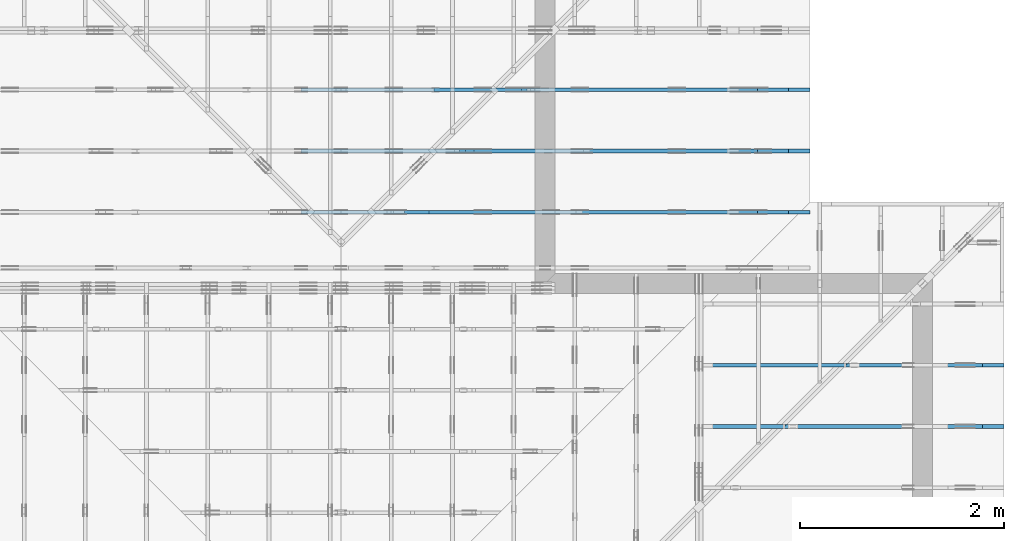
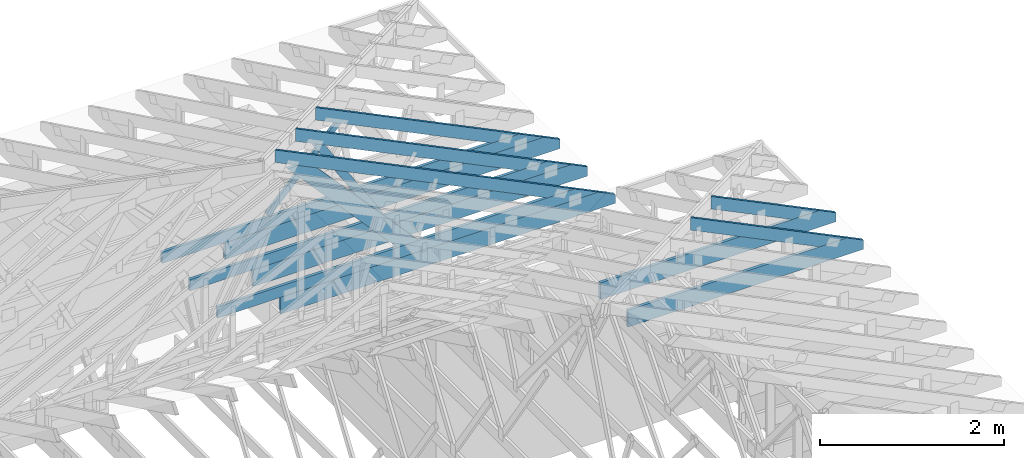
# One storey, part 38 of 159: 16 members, 5 elements without a shape of their own.
"""IFC2X3 building model written with IfcOpenShell, lengths in millimetres."""

from ifc_helpers import new_model, si_unit, frame, origin, origin_with_axes, origin_2d, place, context, project, spatial, faceted_brep, element, aggregate, save


model = new_model("IFC2X3")

# Units and contexts
model_context = context("Model", 3, precision=1e-05, world=origin())
plan_context = context("Plan", 2, precision=1e-05, world=origin_2d())
ifc_project = project(units=[si_unit("LENGTHUNIT", "METRE", prefix="MILLI"), si_unit("AREAUNIT", "SQUARE_METRE"), si_unit("VOLUMEUNIT", "CUBIC_METRE"), si_unit("SOLIDANGLEUNIT", "STERADIAN"), si_unit("PLANEANGLEUNIT", "RADIAN"), si_unit("MASSUNIT", "GRAM"), si_unit("TIMEUNIT", "SECOND"), si_unit("THERMODYNAMICTEMPERATUREUNIT", "DEGREE_CELSIUS"), si_unit("LUMINOUSINTENSITYUNIT", "LUMEN")], contexts=[model_context, plan_context])

# Site, building, storey
site_placement = place(None, origin_with_axes())
site = spatial("IfcSite", under=ifc_project, at=site_placement, CompositionType="ELEMENT")
building_placement = place(site_placement, origin_with_axes())
building = spatial("IfcBuilding", under=site, at=building_placement, Name="Plan 1", CompositionType="ELEMENT")
storey_placement = place(building_placement, origin_with_axes())
storey = spatial("IfcBuildingStorey", under=building, at=storey_placement, Name="Etasje 1", CompositionType="ELEMENT", Elevation=0.0)

# Assembly, members
assembly_1_placement = place(storey_placement, frame((19200.01266310149, 9617.999978540158, 1.1021457184401395e-15), z_axis=(1.2246063538223773e-16, 1.0, 6.123031769111886e-17), x_axis=(-1.0, 1.2246063538223773e-16, 0.0)))
assembly_1 = element("IfcElementAssembly", 1, at=assembly_1_placement, inside=storey, Name="V12 (104)", AssemblyPlace="FACTORY", PredefinedType="TRUSS")
member_1_placement = place(assembly_1_placement, frame((579.5051201688683, 237.97844479869957, -36.00000021700302), z_axis=(0.0, 0.0, 1.0), x_axis=(0.8987940462991673, 0.4383711467890768, 0.0)))
member_1 = element("IfcMember", 2, at=member_1_placement, Name="V12-O21", context=model_context, shape_type="Brep", body=[
    faceted_brep([(4174.996635871784, 148.0000008303515, 2.2522947347169975e-06), (4134.942968873926, 147.99999513818932, 35.9999971857585), (4062.7585449218745, 3.219558948330814e-07, 36.000000217002935), (4102.812214864927, 5.684341886080801e-13, -2.2737367544323206e-13), (9.693633614915598e-05, 148.00000032290794, 2.170030199977191e-07), (9.693633614915598e-05, 148.00000032290794, 36.00000021700302), (4134.9429680300855, 148.00000032290768, 36.00000021700302), (4174.9966370059155, 148.00000032290768, 2.170030199977191e-07), (303.4450508112429, 3.2232911451046675e-07, 2.170030199977191e-07), (303.4450508112429, 3.2232911451046675e-07, 36.00000021700302), (7.909811168360648e-05, 148.00000186326932, 36.00000021700302), (7.909811168360648e-05, 148.00000186326932, 2.170030199977191e-07), (4102.812214780502, 3.219505755503753e-07, 2.170030199977191e-07), (4062.7585458046715, 3.219503612912016e-07, 36.00000021700302), (303.44502728050213, 3.219510518430847e-07, 36.00000021700302), (303.44502728050213, 3.2195127345975504e-07, 2.170030199977191e-07), (4134.942970275878, 148.0000003219552, 36.00000021700302), (0.0, 148.0000003219552, 36.00000021700302), (303.4450683593752, 3.2232941293841577e-07, 36.00000021700302), (4062.758544921875, 3.2232941293841577e-07, 36.00000021700302), (5.585746430369909e-05, 148.00000032329382, 2.1700301999772592e-07), (4174.996637888714, 148.00000032329382, 2.1700353127046008e-07), (4102.81221253471, 3.229042704333551e-07, 2.170035224307095e-07), (303.4451242168394, 3.229042704333551e-07, 2.170030571578018e-07)], [[[0, 1, 2, 3]], [[4, 5, 6, 7]], [[8, 9, 10, 11]], [[12, 13, 14, 15]], [[16, 17, 18, 19]], [[20, 21, 22, 23]]]),
])
member_2_placement = place(assembly_1_placement, frame((4991.181295681745, 371.0000000000011, -36.0), z_axis=(0.0, 0.0, 1.0), x_axis=(-1.0, 1.2246063538223773e-16, 0.0)))
member_2 = element("IfcMember", 3, at=member_2_placement, Name="V12-U34", context=model_context, shape_type="Brep", body=[
    faceted_brep([(4780.000006008893, 148.00000000000168, 36.0), (0.00014333799481391907, 148.00000000000168, 36.0), (0.00014333799481391907, 1.0800249583553523e-12, 36.0), (4476.555013943464, 1.0800249583553523e-12, 36.0), (0.00014333799481391907, 148.00000000000168, 1.7553261919328425e-20), (4780.000006008893, 148.00000000000168, 5.853618378629492e-13), (4476.555013943464, 1.0800249583553523e-12, 5.482017713310586e-13), (0.00014333799481391907, 1.0800249583553523e-12, 1.7553261919328425e-20), (0.0, 0.0, 0.0), (2.204291436880279e-15, -2.6993892992798474e-31, 36.0), (2.0328465473451462e-14, 148.0, 36.0), (1.8124174036571183e-14, 148.0, -1.1097489341483817e-30), (4476.555031444877, -8.223026602114393e-13, 1.5128553039240036e-28), (4476.555031444877, -8.20098368774559e-13, 36.0), (4.049083948919771e-31, 2.204291436880279e-15, 36.0), (0.0, 0.0, 0.0), (4780.0, 148.00000000000227, -5.048709793414476e-29), (4780.0, 148.00000000000227, 36.0), (4476.555031444878, 2.5011104298755527e-12, 36.0), (4476.555031444878, 2.5011104298755527e-12, -2.524354896707238e-29), (0.0, 148.0, 0.0), (0.0, 148.0, 36.0), (4780.0, 148.00000000000182, 36.0), (4780.0, 148.00000000000182, 9.466330862652142e-30)], [[[0, 1, 2, 3]], [[4, 5, 6, 7]], [[8, 9, 10, 11]], [[12, 13, 14, 15]], [[16, 17, 18, 19]], [[20, 21, 22, 23]]]),
])
member_3_placement = place(assembly_1_placement, frame((3965.2348718633434, 2028.64517936101, -36.0), z_axis=(0.0, 0.0, 1.0), x_axis=(-0.6709049751762265, -0.741543332708067, 0.0)))
member_3 = element("IfcMember", 4, at=member_3_placement, Name="V12-D1", context=model_context, shape_type="Brep", body=[
    faceted_brep([(2056.260085863651, 198.00005558195403, 36.0), (0.0, 198.00005558195403, 36.0), (89.5695814747055, 98.99992943772486, 36.0), (336.2995013158579, 0.0, 36.0), (2235.3989212227416, 0.0, 36.0), (0.0, 198.00005558195403, 0.0), (2056.260085863651, 198.00005558195403, 2.5181091662599743e-13), (2235.3989212227416, 0.0, 2.7374837222570574e-13), (336.2995013158579, 0.0, 4.118345060986965e-14), (89.5695814747055, 98.99992943772486, 1.0968747858313546e-14), (89.56955245042903, 99.00003776664154, -1.4956299890023215e-30), (89.56955245042903, 99.00003776664154, 36.0), (0.00015088908645566335, 198.0000377666693, 36.0), (0.00015088908645566335, 198.0000377666693, -2.250561573344035e-30), (336.29944270350006, 3.776666927990391e-05, -1.5777218104420236e-30), (336.29944270350006, 3.776666927990391e-05, 36.0), (89.569552450429, 99.00003776664155, 36.0), (89.569552450429, 99.00003776664155, -1.5777218104420236e-30), (2235.3989051045114, 3.7766668814806337e-05, 4.1530098805511816e-29), (2235.3989051045114, 3.776666881701063e-05, 36.0), (336.29944270350006, 3.7766669165858023e-05, 36.0), (336.29944270350006, 3.776666916365373e-05, 6.247899928631825e-30), (2056.2601019818762, 198.00003776667006, 0.0), (2056.2601019818762, 198.00003776667006, 36.0), (2235.3989051045114, 3.776666949306673e-05, 36.0), (2235.3989051045114, 3.776666949306673e-05, 0.0), (0.00015088908639881995, 198.00003776666927, 0.0), (0.00015088908639881995, 198.00003776666927, 36.0), (2056.2601019818762, 198.00003776667006, 36.0), (2056.2601019818762, 198.00003776667006, -7.888609052210118e-30)], [[[0, 1, 2, 3, 4]], [[5, 6, 7, 8, 9]], [[10, 11, 12, 13]], [[14, 15, 16, 17]], [[18, 19, 20, 21]], [[22, 23, 24, 25]], [[26, 27, 28, 29]]]),
])
member_4_placement = place(assembly_1_placement, frame((4200.000000000012, 223.0, -36.0), z_axis=(0.0, 0.0, 1.0), x_axis=(-1.0, 1.2246063538223773e-16, 0.0)))
member_4 = element("IfcMember", 5, at=member_4_placement, Name="V12-U9", context=model_context, shape_type="Brep", body=[
    faceted_brep([(4200.000000000031, 223.0, 36.0), (1.1823431123048067e-11, 223.0, 36.0), (1.1823431123048067e-11, 0.0, 36.0), (3988.8187103271603, 0.0, 36.0), (4200.000000000018, 103.00000000000051, 36.0), (1.1823431123048067e-11, 223.0, 1.4479048877265909e-27), (4200.000000000031, 223.0, 5.143346686054023e-13), (4200.000000000018, 103.00000000000051, 5.143346686054007e-13), (3988.8187103271603, 4.831690603168681e-13, 4.884732736912221e-13), (1.1823431123048067e-11, 4.831690603168681e-13, 1.4479048877265909e-27), (3988.8187043209837, -7.327099094335529e-13, 7.444865559176857e-29), (3988.8187043209837, -7.305056179966726e-13, 36.0), (4.049083948919771e-31, 2.204291436880279e-15, 36.0), (0.0, 0.0, 0.0), (4200.000000000018, 102.99999999809165, 6.310887241768094e-29), (4200.000000000018, 102.99999999809165, 36.0), (3988.8187043209837, -4.547473508864641e-13, 36.0), (3988.8187043209837, -4.547473508864641e-13, 6.310887241768094e-29), (4200.000000000007, 223.0000000000005, -1.464125840090198e-27), (4200.000000000007, 223.0000000000005, 36.0), (4200.000000000007, 102.99999999809279, 36.0), (4200.000000000007, 102.99999999809279, -6.563322731438818e-28), (2.3646862246096134e-11, 223.0, 0.0), (2.3646862246096134e-11, 223.0, 36.0), (4200.000000000031, 223.00000000000068, 36.0), (4200.000000000031, 223.00000000000068, 9.466330862652142e-30), (0.0, 0.0, 0.0), (2.204291436880279e-15, -2.342275270834659e-28, 36.0), (2.3698135630505907e-11, 223.0, 36.0), (2.3695931339069026e-11, 223.0, -3.0045161515452303e-30)], [[[0, 1, 2, 3, 4]], [[5, 6, 7, 8, 9]], [[10, 11, 12, 13]], [[14, 15, 16, 17]], [[18, 19, 20, 21]], [[22, 23, 24, 25]], [[26, 27, 28, 29]]]),
])
aggregate(assembly_1, [member_1, member_2, member_3, member_4])

assembly_2_placement = place(storey_placement, frame((21100.012663101486, 8117.993668449257, 1.1021457184401395e-15), z_axis=(1.2246063538223773e-16, 1.0, 6.123031769111886e-17), x_axis=(-1.0, 1.2246063538223773e-16, 0.0)))
assembly_2 = element("IfcElementAssembly", 6, at=assembly_2_placement, inside=storey, Name="S19 (48)", AssemblyPlace="FACTORY", PredefinedType="TRUSS")
member_5_placement = place(assembly_2_placement, frame((276.06017505105154, 89.97845623023335, -36.00000021758372), z_axis=(0.0, 0.0, 1.0), x_axis=(0.8987940462991671, 0.438371146789077, 0.0)))
member_5 = element("IfcMember", 7, at=member_5_placement, Name="S19-O62", context=model_context, shape_type="Brep", body=[
    faceted_brep([(1508.5918758480043, 148.00000083082796, 2.253368961646629e-06), (1468.5382088506674, 147.9999951378851, 35.999997187413555), (1396.3537848995943, 3.211747525710962e-07, 36.000000217583874), (1436.4074548421263, -5.684341886080802e-14, 1.1368683772161603e-13), (1.5777218104420236e-29, 148.00000032213524, 2.175837181539464e-07), (-3.1554436208840472e-30, 148.00000032213535, 36.00000021758372), (1468.5382080078125, 148.00000032213558, 36.00000021758372), (1508.5918769836424, 148.0000003221355, 2.175837181539464e-07), (303.4450247380253, 3.203389837835857e-07, 2.175837181539464e-07), (303.4450247380253, 3.203389837835857e-07, 36.00000021758372), (5.302489400094146e-05, 148.00000186127926, 36.00000021758372), (5.302489400094146e-05, 148.00000186127926, 2.175837181539464e-07), (1436.4074547566977, 3.2120499840740995e-07, 2.175837181539464e-07), (1396.3537857808676, 3.21205007969198e-07, 36.00000021758372), (303.44505241294786, 3.212052087266449e-07, 36.00000021758372), (303.44505241294786, 3.2120520652235344e-07, 2.175837181539464e-07), (1468.538210253598, 148.00000032117475, 36.00000021758372), (2.5133969302260084e-05, 148.00000032117475, 36.00000021758372), (303.44497142303175, 3.2033921115726116e-07, 36.00000021758372), (1396.3537848995943, 3.2033921115726116e-07, 36.00000021758372), (8.098991014549028e-05, 148.0000003213039, 2.1758371815395632e-07), (1508.59187786491, 148.0000003213039, 2.175839028970663e-07), (1436.407452510906, 3.2215814371738816e-07, 2.1758389405731569e-07), (303.4450272789724, 3.2215814371738816e-07, 2.1758375531401723e-07)], [[[0, 1, 2, 3]], [[4, 5, 6, 7]], [[8, 9, 10, 11]], [[12, 13, 14, 15]], [[16, 17, 18, 19]], [[20, 21, 22, 23]]]),
])
member_6_placement = place(assembly_2_placement, frame((2953.4710103785837, 223.0, -36.0), z_axis=(0.0, 0.0, 1.0), x_axis=(-1.0, 1.2246063538223773e-16, 0.0)))
member_6 = element("IfcMember", 8, at=member_6_placement, Name="S19-U10", context=model_context, shape_type="Brep", body=[
    faceted_brep([(2953.4710103785947, 223.00000000000037, 36.0), (6.311295874183998e-05, 223.00000000000037, 36.0), (6.311295874183998e-05, 0.0, 36.0), (2742.289720705732, 0.0, 36.0), (2953.4700660270973, 102.9995422363285, 36.0), (6.311295874183998e-05, 223.00000000000037, 7.728853028378678e-21), (2953.4710103785947, 223.00000000000037, 3.616839365139823e-13), (2953.4700660270973, 102.9995422363285, 3.6168382086809796e-13), (2742.289720705732, 0.0, 3.358225415998032e-13), (6.311295874183998e-05, 0.0, 7.728853028378678e-21), (0.0, 0.0, 0.0), (2.204291436880279e-15, -2.6993892992798474e-31, 36.0), (2.951301312711929e-14, 223.0, 36.0), (2.7308721690239013e-14, 223.0, -1.6721217048316832e-30), (2742.2897146949763, -5.037338112955833e-13, 5.172702487036636e-29), (2742.2897146949763, -5.01529519858703e-13, 36.0), (4.049083948919771e-31, 2.204291436880279e-15, 36.0), (0.0, 0.0, 0.0), (2953.4700660271087, 102.99953940881801, 5.880623194680879e-29), (2953.4700660271087, 102.99953940881801, 36.0), (2742.2897146949767, -2.2737367544323206e-13, 36.0), (2742.2897146949767, -2.2737367544323206e-13, 4.546043208465161e-29), (2953.469255282577, 223.00000000000037, -1.0746508672931903e-19), (2953.469255282577, 223.00000000000037, 36.0), (2953.469255282577, 102.9995394088186, 36.0), (2953.469255282577, 102.9995394088186, -4.9642145206786636e-20), (0.0, 223.0, 0.0), (0.0, 223.0, 36.0), (2953.4710103785947, 223.00000000000048, 36.0), (2953.4710103785947, 223.00000000000048, 6.310887241768095e-30)], [[[0, 1, 2, 3, 4]], [[5, 6, 7, 8, 9]], [[10, 11, 12, 13]], [[14, 15, 16, 17]], [[18, 19, 20, 21]], [[22, 23, 24, 25]], [[26, 27, 28, 29]]]),
])
aggregate(assembly_2, [member_5, member_6])

assembly_3_placement = place(storey_placement, frame((21100.012663101486, 7517.993668449257, 1.1021457184401395e-15), z_axis=(1.2246063538223773e-16, 1.0, 6.123031769111886e-17), x_axis=(-1.0, 1.2246063538223773e-16, 0.0)))
assembly_3 = element("IfcElementAssembly", 9, at=assembly_3_placement, inside=storey, Name="S18 (46)", AssemblyPlace="FACTORY", PredefinedType="TRUSS")
member_7_placement = place(assembly_3_placement, frame((276.0601444724039, 89.97844131552674, -36.00000021759615), z_axis=(0.0, 0.0, 1.0), x_axis=(0.8987940462991671, 0.4383711467890766, 0.0)))
member_7 = element("IfcMember", 10, at=member_7_placement, Name="S18-O53", context=model_context, shape_type="Brep", body=[
    faceted_brep([(2176.1530741549623, 148.00000083083336, 2.2533438368554926e-06), (2136.099407157636, 147.99999513788833, 35.99999718740048), (2063.914983206573, 3.211728198948549e-07, 36.00000021759615), (2103.9686531490943, 5.684341886080802e-14, 0.0), (4.1080398432313814e-05, 148.00000032209752, 2.175961526518222e-07), (4.1080398432313814e-05, 148.0000003220973, 36.00000021759615), (2136.0994063147737, 148.00000032209715, 36.00000021759615), (2176.1530752906037, 148.00000032209738, 2.175961526518222e-07), (303.44505876010885, 3.2079194056677807e-07, 2.175961526518222e-07), (303.44505876010885, 3.2079194056677807e-07, 36.00000021759615), (8.70469773914806e-05, 148.00000186173193, 36.00000021759615), (8.70469773914806e-05, 148.00000186173193, 2.175961526518222e-07), (2103.968653063663, 3.211812537246828e-07, 2.175961526518222e-07), (2063.9149840878326, 3.211811433823842e-07, 36.00000021759615), (303.44509349335044, 3.2118146676477625e-07, 36.00000021759615), (303.44509349335044, 3.2118158446457147e-07, 2.175961526518222e-07), (2136.099408560577, 148.00000032117305, 36.00000021759615), (0.00018828469814025084, 148.00000032117305, 36.00000021759615), (303.4450125034482, 3.207921395187441e-07, 36.00000021759615), (2063.914983206573, 3.207921395187441e-07, 36.00000021759615), (0.0, 148.00000032012335, 2.175961526518222e-07), (2176.153076171875, 148.00000032012335, 2.1759641914491058e-07), (2103.9686508178715, 3.221342694814666e-07, 2.1759641030516e-07), (303.445068359375, 3.221342694814666e-07, 2.1759618981189806e-07)], [[[0, 1, 2, 3]], [[4, 5, 6, 7]], [[8, 9, 10, 11]], [[12, 13, 14, 15]], [[16, 17, 18, 19]], [[20, 21, 22, 23]]]),
])
member_8_placement = place(assembly_3_placement, frame((2953.4710103785837, 223.0, -36.0), z_axis=(0.0, 0.0, 1.0), x_axis=(-1.0, 1.2246063538223773e-16, 0.0)))
member_8 = element("IfcMember", 11, at=member_8_placement, Name="S18-U10", context=model_context, shape_type="Brep", body=[
    faceted_brep([(2953.4710103785947, 223.00000000000037, 36.0), (6.311295874183998e-05, 223.00000000000037, 36.0), (6.311295874183998e-05, 0.0, 36.0), (2742.289720705732, 0.0, 36.0), (2953.4700660270973, 102.9995422363285, 36.0), (6.311295874183998e-05, 223.00000000000037, 7.728853028378678e-21), (2953.4710103785947, 223.00000000000037, 3.616839365139823e-13), (2953.4700660270973, 102.9995422363285, 3.6168382086809796e-13), (2742.289720705732, 0.0, 3.358225415998032e-13), (6.311295874183998e-05, 0.0, 7.728853028378678e-21), (0.0, 0.0, 0.0), (2.204291436880279e-15, -2.6993892992798474e-31, 36.0), (2.951301312711929e-14, 223.0, 36.0), (2.7308721690239013e-14, 223.0, -1.6721217048316832e-30), (2742.2897146949763, -5.037338112955833e-13, 5.172702487036636e-29), (2742.2897146949763, -5.01529519858703e-13, 36.0), (4.049083948919771e-31, 2.204291436880279e-15, 36.0), (0.0, 0.0, 0.0), (2953.4700660271083, 102.9995394088487, -7.573064690121713e-29), (2953.4700660271083, 102.9995394088487, 36.0), (2742.289714694976, 1.1368683772161603e-12, 36.0), (2742.289714694976, 1.1368683772161603e-12, -6.310887241768094e-29), (2953.4692552825763, 223.00000000000037, -1.0746508677980613e-19), (2953.4692552825763, 223.00000000000037, 36.0), (2953.4692552825763, 102.99953940884771, 36.0), (2953.4692552825763, 102.99953940884771, -4.9642145257273734e-20), (0.0, 223.0, 0.0), (0.0, 223.0, 36.0), (2953.4710103785947, 223.00000000000048, 36.0), (2953.4710103785947, 223.00000000000048, 6.310887241768095e-30)], [[[0, 1, 2, 3, 4]], [[5, 6, 7, 8, 9]], [[10, 11, 12, 13]], [[14, 15, 16, 17]], [[18, 19, 20, 21]], [[22, 23, 24, 25]], [[26, 27, 28, 29]]]),
])
aggregate(assembly_3, [member_7, member_8])

assembly_4_placement = place(storey_placement, frame((19200.01266310149, 10817.999978540158, 1.1021457184401395e-15), z_axis=(1.2246063538223773e-16, 1.0, 6.123031769111886e-17), x_axis=(-1.0, 1.2246063538223773e-16, 0.0)))
assembly_4 = element("IfcElementAssembly", 12, at=assembly_4_placement, inside=storey, Name="V10 (59)", AssemblyPlace="FACTORY", PredefinedType="TRUSS")
member_9_placement = place(assembly_4_placement, frame((579.5051074803984, 237.97843861159637, -36.00000021716696), z_axis=(0.0, 0.0, 1.0), x_axis=(0.8987940462991675, 0.43837114678907646, 0.0)))
member_9 = element("IfcMember", 13, at=member_9_placement, Name="V10-O41/", context=model_context, shape_type="Brep", body=[
    faceted_brep([(2839.8743214182064, 148.00000083050088, 2.2526157863467233e-06), (2799.8206544204945, 147.99999513810508, 35.99999718624326), (2727.6362304687505, 3.2172215469472576e-07, 36.00000021716778), (2767.6899004116567, -2.2737367544323206e-13, 9.094947017729282e-13), (9.693471713489998e-05, 148.0000003193544, 2.1716696352314102e-07), (9.693471713489998e-05, 148.00000031935463, 36.00000021716697), (2799.820653575342, 148.00000031935446, 36.00000021716697), (2839.874322551172, 148.00000031935423, 2.1716696352314102e-07), (303.445064929486, 3.2018495232932764e-07, 2.1716696352314102e-07), (303.445064929486, 3.2018495232932764e-07, 36.00000021716696), (9.321635457126831e-05, 148.00000186112496, 36.00000021716696), (9.321635457126831e-05, 148.00000186112496, 2.1716696352314102e-07), (2767.689900326961, 3.2174721183431663e-07, 2.1716696352314102e-07), (2727.636231351131, 3.2174722139610464e-07, 36.00000021716696), (303.44502728008604, 3.217476666980974e-07, 36.00000021716696), (303.44502728008604, 3.2174766449380594e-07, 2.1716696352314102e-07), (2799.8206558227535, 148.00000032172215, 36.00000021716696), (0.0, 148.00000032172215, 36.00000021716696), (303.44506835937443, 3.201851086487295e-07, 36.00000021716696), (2727.6362304687495, 3.201851086487295e-07, 36.00000021716696), (5.585541532582283e-05, 148.0000003195164, 2.1716696352314785e-07), (2839.8743234335398, 148.0000003195164, 2.1716731129595508e-07), (2767.689898079536, 3.193524662492564e-07, 2.171673024562045e-07), (303.44512421478976, 3.193524662492564e-07, 2.1716700068322374e-07)], [[[0, 1, 2, 3]], [[4, 5, 6, 7]], [[8, 9, 10, 11]], [[12, 13, 14, 15]], [[16, 17, 18, 19]], [[20, 21, 22, 23]]]),
])
member_10_placement = place(assembly_4_placement, frame((4991.1812956836075, 371.00000000093075, -36.0), z_axis=(0.0, 0.0, 1.0), x_axis=(-1.0, 1.2246063538223773e-16, 0.0)))
member_10 = element("IfcMember", 14, at=member_10_placement, Name="V10-U34", context=model_context, shape_type="Brep", body=[
    faceted_brep([(4780.000006010756, 148.00000000093135, 36.0), (0.0001433398574590683, 148.00000000093135, 36.0), (0.0001433398574590683, 9.307541404268704e-10, 36.0), (4476.555013945326, 9.307541404268704e-10, 36.0), (0.0001433398574590683, 148.00000000093135, 1.755349002003689e-20), (4780.000006010756, 148.00000000093135, 5.853618378631773e-13), (4476.555013945326, 9.307541404268704e-10, 5.482017713312867e-13), (0.0001433398574590683, 9.307541404268704e-10, 1.755349002003689e-20), (1.1387632720345817e-25, 9.299014891439583e-10, -6.972683692165545e-42), (2.2042914369941555e-15, 9.299014891439583e-10, 36.0), (2.032846547356534e-14, 148.0000000009299, 36.0), (1.812417403668506e-14, 148.0000000009299, -1.1097489341553544e-30), (4476.55503144674, -1.3000337225098477e-12, 7.960147783844159e-29), (4476.55503144674, -1.2978294310729674e-12, 36.0), (4.585310642683174e-28, 9.299036934353952e-10, 36.0), (0.0, 9.299014891439583e-10, 0.0), (4780.000000000001, 148.00000000093064, 5.048709793414476e-29), (4780.000000000001, 148.00000000093064, 36.0), (4476.555031446741, -9.094947017729282e-13, 36.0), (4476.555031446741, -9.094947017729282e-13, 5.048709793414476e-29), (0.0, 148.0000000009299, 0.0), (0.0, 148.0000000009299, 36.0), (4780.0, 148.00000000093172, 36.0), (4780.0, 148.00000000093172, 2.3665827156630354e-29)], [[[0, 1, 2, 3]], [[4, 5, 6, 7]], [[8, 9, 10, 11]], [[12, 13, 14, 15]], [[16, 17, 18, 19]], [[20, 21, 22, 23]]]),
])
member_11_placement = place(assembly_4_placement, frame((2744.0394978392, 1293.692400218844, -35.99999999999999), z_axis=(0.0, 0.0, 1.0), x_axis=(0.6960143876995056, -0.7180278351953231, 0.0)))
member_11 = element("IfcMember", 15, at=member_11_placement, Name="V10-D40", context=model_context, shape_type="Brep", body=[
    faceted_brep([(1282.7637258409495, 73.00006807234877, 36.0), (47.316733297285396, 73.00006807234877, 36.0), (11.935718713581196, 36.49998031358882, 36.0), (4.934666799272236e-05, 2.589879932202166e-05, 36.0), (1285.0371225740018, 2.589879932202166e-05, 36.0), (47.316733297285396, 73.00006807234877, 5.794437223797454e-15), (1282.7637258409495, 73.00006807234877, 1.5708806091176928e-13), (1285.0371225740018, 2.589879932202166e-05, 1.5736646252017476e-13), (4.934666799272236e-05, 2.589879932202166e-05, 6.043024316385114e-21), (11.935718713581196, 36.49998031358882, 1.4616556974088183e-15), (11.935754754354774, 36.49999999806095, -6.071484783209866e-31), (11.935754754354774, 36.49999999806095, 36.0), (47.31673012485851, 72.99999999999999, 36.0), (47.31673012485851, 72.99999999999999, -1.3148656957199195e-30), (-7.300694593112398e-16, 4.549860886952435e-13, 4.703178611267528e-32), (1.3650473213638964e-15, 4.543009708849093e-13, 36.0), (11.935754754354777, 36.499999998060964, 36.0), (11.935754754354775, 36.499999998060964, 1.224891444630282e-31), (1285.0370904733404, 2.1869766300280306e-13, -1.3390927383966882e-29), (1285.0370904733404, 2.2090195443968334e-13, 36.0), (4.049083948919771e-31, 4.569516423233444e-13, 36.0), (0.0, 4.547473508864641e-13, 0.0), (1282.7636488541218, 73.00000000000091, 1.2621774483536192e-29), (1282.7636488541218, 73.00000000000091, 36.0), (1285.0370904733406, -7.105427357601002e-15, 36.0), (1285.0370904733406, -7.105427357601002e-15, 1.2621774483536192e-29), (47.31673012485851, 73.00000000000001, 1.5777218104420236e-30), (47.31673012485851, 73.00000000000001, 36.0), (1282.7636488541216, 73.00000000000132, 36.0), (1282.7636488541216, 73.00000000000132, 2.4454688061851366e-29)], [[[0, 1, 2, 3, 4]], [[5, 6, 7, 8, 9]], [[10, 11, 12, 13]], [[14, 15, 16, 17]], [[18, 19, 20, 21]], [[22, 23, 24, 25]], [[26, 27, 28, 29]]]),
])
member_12_placement = place(assembly_4_placement, frame((4200.000000000024, 223.0, -36.0), z_axis=(0.0, 0.0, 1.0), x_axis=(-1.0, 1.062597817895472e-13, 0.0)))
member_12 = element("IfcMember", 16, at=member_12_placement, Name="V10-U9", context=model_context, shape_type="Brep", body=[
    faceted_brep([(4200.000000000012, 223.0, 36.0), (0.0, 223.0, 36.0), (2.3646862246096134e-11, 0.0, 36.0), (3988.818710327172, 0.0, 36.0), (4200.000000000012, 103.00000000044628, 36.0), (0.0, 223.0, 0.0), (4200.000000000012, 223.0, 5.143346686053999e-13), (4200.000000000012, 103.00000000044628, 5.143346686053999e-13), (3988.818710327172, 4.2382453102618456e-10, 4.884732736912236e-13), (2.3646862246096134e-11, 4.2382453102618456e-10, 2.8958097754531817e-27), (3988.8187043209955, 4.2440121328345996e-10, -3.5310437819802764e-29), (3988.8187043209955, 4.2440341757489684e-10, 36.0), (1.1823431123048067e-11, 2.2042914368819885e-15, 36.0), (1.1823431123048067e-11, 1.709368977184308e-27, -1.0466520552433773e-43), (4200.000000000013, 102.9999999985373, 1.135959703518257e-28), (4200.000000000013, 102.9999999985373, 36.0), (3988.8187043209964, 4.2246028897352517e-10, 36.0), (3988.8187043209964, 4.2246028897352517e-10, 1.0097419586828951e-28), (4200.000000000012, 223.00000000044628, 0.0), (4200.000000000012, 223.00000000044628, 36.0), (4200.000000000012, 102.99999999853861, 36.0), (4200.000000000012, 102.99999999853861, 0.0), (1.1823431123048067e-11, 223.0, 0.0), (1.1823431123048067e-11, 223.0, 36.0), (4200.000000000012, 223.00000000044645, 36.0), (4200.000000000012, 223.00000000044645, 1.1044052673094165e-29), (1.1823431123048067e-11, 0.0, 0.0), (1.1825635414484947e-11, -2.6993892992798474e-31, 36.0), (1.1852944136175186e-11, 223.0, 36.0), (1.1850739844738306e-11, 223.0, -1.6721217048316832e-30)], [[[0, 1, 2, 3, 4]], [[5, 6, 7, 8, 9]], [[10, 11, 12, 13]], [[14, 15, 16, 17]], [[18, 19, 20, 21]], [[22, 23, 24, 25]], [[26, 27, 28, 29]]]),
])
aggregate(assembly_4, [member_9, member_10, member_11, member_12])

assembly_5_placement = place(storey_placement, frame((19200.01266310149, 10217.999978540158, 1.1021457184401395e-15), z_axis=(1.2246063538223773e-16, 1.0, 6.123031769111886e-17), x_axis=(-1.0, 1.2246063538223773e-16, 0.0)))
assembly_5 = element("IfcElementAssembly", 17, at=assembly_5_placement, inside=storey, Name="V11 (60)", AssemblyPlace="FACTORY", PredefinedType="TRUSS")
member_13_placement = place(assembly_5_placement, frame((579.5050912336225, 237.97843068680686, -36.000000217113985), z_axis=(0.0, 0.0, 1.0), x_axis=(0.8987940462991674, 0.4383711467890765, 0.0)))
member_13 = element("IfcMember", 18, at=member_13_placement, Name="V11-O31", context=model_context, shape_type="Brep", body=[
    faceted_brep([(3507.4355037796977, 148.00000083045688, 2.2524113774125e-06), (3467.3818367819376, 147.99999513815874, 35.99999718598633), (3395.1974128301026, 3.2181992537516635e-07, 36.000000217112984), (3435.2510827730575, 2.2737367544323206e-13, -1.1368683772161603e-12), (0.0, 148.00000032109944, 2.171139925621901e-07), (0.0, 148.00000032109944, 36.00000021711399), (3467.3818359374995, 148.0000003210992, 36.00000021711399), (3507.4355049133296, 148.0000003210992, 2.171139925621901e-07), (303.44508300431636, 3.2163765695258917e-07, 2.171139925621901e-07), (303.44508300431636, 3.2163765695258917e-07, 36.00000021711399), (0.00011129118488639733, 148.00000186257768, 36.00000021711399), (0.00011129118488639733, 148.00000186257768, 2.171139925621901e-07), (3435.2510826885205, 3.218216304384347e-07, 2.171139925621901e-07), (3395.1974137126904, 3.2182140818565525e-07, 36.00000021711399), (303.44517448539557, 3.2182197611257076e-07, 36.00000021711399), (303.44517448539557, 3.2182220572284686e-07, 2.171139925621901e-07), (3467.381838184108, 148.00000032181947, 36.00000021711399), (0.00014720510409915732, 148.00000032181947, 36.00000021711399), (303.4449714238541, 3.2163802643481176e-07, 36.00000021711399), (3395.1974128301035, 3.2163802643481176e-07, 36.00000021711399), (0.00020306154090121709, 148.00000032096938, 2.1711399256221496e-07), (3507.435505795916, 148.00000032096938, 2.171144220849707e-07), (3435.2510804419117, 3.2110096981341485e-07, 2.1711441324522012e-07), (303.4450272802909, 3.2110096981341485e-07, 2.1711402972226094e-07)], [[[0, 1, 2, 3]], [[4, 5, 6, 7]], [[8, 9, 10, 11]], [[12, 13, 14, 15]], [[16, 17, 18, 19]], [[20, 21, 22, 23]]]),
])
member_14_placement = place(assembly_5_placement, frame((4991.181295681745, 371.00000000000114, -36.0), z_axis=(0.0, 0.0, 1.0), x_axis=(-1.0, 1.2246063538223773e-16, 0.0)))
member_14 = element("IfcMember", 19, at=member_14_placement, Name="V11-U34", context=model_context, shape_type="Brep", body=[
    faceted_brep([(4780.000006008893, 148.00000000000173, 36.0), (0.00014333799481391907, 148.00000000000173, 36.0), (0.00014333799481391907, 1.1368683772161603e-12, 36.0), (4476.555013943464, 1.1368683772161603e-12, 36.0), (0.00014333799481391907, 148.00000000000173, 1.7553261919328425e-20), (4780.000006008893, 148.00000000000173, 5.853618378629492e-13), (4476.555013943464, 1.1368683772161603e-12, 5.482017713310586e-13), (0.00014333799481391907, 1.1368683772161603e-12, 1.7553261919328425e-20), (0.0, 0.0, 0.0), (2.204291436880279e-15, -2.6993892992798474e-31, 36.0), (2.0328465473451462e-14, 148.0, 36.0), (1.8124174036571183e-14, 148.0, -1.1097489341483817e-30), (4476.555031444877, -8.223026602114393e-13, 1.5476607098789697e-28), (4476.555031444877, -8.20098368774559e-13, 36.0), (4.049083948919771e-31, 2.204291436880279e-15, 36.0), (0.0, 0.0, 0.0), (4780.0, 148.00000000000227, -5.048709793414476e-29), (4780.0, 148.00000000000227, 36.0), (4476.555031444878, 2.5011104298755527e-12, 36.0), (4476.555031444878, 2.5011104298755527e-12, -2.524354896707238e-29), (0.0, 148.0, 0.0), (0.0, 148.0, 36.0), (4780.0, 148.00000000000182, 36.0), (4780.0, 148.00000000000182, 6.310887241768095e-30)], [[[0, 1, 2, 3]], [[4, 5, 6, 7]], [[8, 9, 10, 11]], [[12, 13, 14, 15]], [[16, 17, 18, 19]], [[20, 21, 22, 23]]]),
])
member_15_placement = place(assembly_5_placement, frame((3353.721017009095, 1655.5622080945388, -36.0), z_axis=(0.0, 0.0, 1.0), x_axis=(-0.5346520927149746, -0.8450722689542582, 0.0)))
member_15 = element("IfcMember", 20, at=member_15_placement, Name="V11-D7", context=model_context, shape_type="Brep", body=[
    faceted_brep([(1458.0602561801911, 98.00002627175809, 36.0), (4.372323292045621e-05, 98.00002627175809, 36.0), (31.000858510272337, 49.00005600852319, 36.0), (110.40158214144867, 0.0, 36.0), (1520.06188575427, 0.0, 36.0), (4.372323292045621e-05, 98.00002627175809, 5.354374884404641e-21), (1458.0602561801911, 98.00002627175809, 1.785549853974145e-13), (1520.06188575427, 0.0, 1.8614774434979036e-13), (110.40158214144867, 0.0, 1.3519847896246113e-14), (31.000858510272337, 49.00005600852319, 3.796384830562802e-15), (31.000842775420104, 49.00007050769979, -3.944304526105059e-31), (31.000842775420104, 49.00007050769979, 36.0), (1.4210854715202004e-14, 98.00007050898013, 36.0), (1.4210854715202004e-14, 98.00007050898013, -1.1832913578315177e-30), (110.40157689236092, 7.05089800661085e-05, 3.1554436208840472e-30), (110.40157689236092, 7.05089800661085e-05, 36.0), (31.000842775420093, 49.00007050769977, 36.0), (31.000842775420093, 49.00007050769977, 0.0), (1520.0619137418348, 7.050898107986654e-05, 2.450572069147932e-29), (1520.0619137418348, 7.050898108207083e-05, 36.0), (110.40157689236094, 7.05089800889828e-05, 36.0), (110.40157689236094, 7.050898008677851e-05, 1.7798421395743878e-30), (1458.0602281926149, 98.0000705089825, 2.524354896707238e-29), (1458.0602281926149, 98.0000705089825, 36.0), (1520.061913741835, 7.050898159377539e-05, 36.0), (1520.061913741835, 7.050898159377539e-05, 2.524354896707238e-29), (0.0, 98.00007050898012, 0.0), (0.0, 98.00007050898012, 36.0), (1458.0602281926147, 98.00007050898229, 36.0), (1458.0602281926147, 98.00007050898229, -6.310887241768095e-30)], [[[0, 1, 2, 3, 4]], [[5, 6, 7, 8, 9]], [[10, 11, 12, 13]], [[14, 15, 16, 17]], [[18, 19, 20, 21]], [[22, 23, 24, 25]], [[26, 27, 28, 29]]]),
])
member_16_placement = place(assembly_5_placement, frame((4200.000000000012, 223.0, -36.0), z_axis=(0.0, 0.0, 1.0), x_axis=(-1.0, 1.2246063538223773e-16, 0.0)))
member_16 = element("IfcMember", 21, at=member_16_placement, Name="V11-U9", context=model_context, shape_type="Brep", body=[
    faceted_brep([(4200.0, 223.0, 36.0), (1.1823431123048067e-11, 223.0, 36.0), (1.1823431123048067e-11, 0.0, 36.0), (3988.8187103271603, 0.0, 36.0), (4200.0, 103.00000000000051, 36.0), (1.1823431123048067e-11, 223.0, 1.4479048877265909e-27), (4200.0, 223.0, 5.143346686053984e-13), (4200.0, 103.00000000000051, 5.143346686053984e-13), (3988.8187103271603, 4.831690603168681e-13, 4.884732736912221e-13), (1.1823431123048067e-11, 4.831690603168681e-13, 1.4479048877265909e-27), (3988.8187043209837, -7.327099094335529e-13, 7.444865559176857e-29), (3988.8187043209837, -7.305056179966726e-13, 36.0), (4.049083948919771e-31, 2.204291436880279e-15, 36.0), (0.0, 0.0, 0.0), (4199.999999999999, 102.99999999809552, -1.6408306828597046e-28), (4199.999999999999, 102.99999999809552, 36.0), (3988.8187043209823, 2.7284841053187847e-12, 36.0), (3988.8187043209823, 2.7284841053187847e-12, -1.5146129380243427e-28), (4200.0, 223.0000000000005, 0.0), (4200.0, 223.0000000000005, 36.0), (4200.0, 102.99999999809299, 36.0), (4200.0, 102.99999999809299, 0.0), (0.0, 223.0, 0.0), (0.0, 223.0, 36.0), (4200.0, 223.00000000000068, 36.0), (4200.0, 223.00000000000068, 9.466330862652142e-30), (0.0, 0.0, 0.0), (2.204291436880279e-15, -2.6993892992798474e-31, 36.0), (2.951301312711929e-14, 223.0, 36.0), (2.7308721690239013e-14, 223.0, -1.6721217048316832e-30)], [[[0, 1, 2, 3, 4]], [[5, 6, 7, 8, 9]], [[10, 11, 12, 13]], [[14, 15, 16, 17]], [[18, 19, 20, 21]], [[22, 23, 24, 25]], [[26, 27, 28, 29]]]),
])
aggregate(assembly_5, [member_13, member_14, member_15, member_16])

save(model, "model.ifc")
